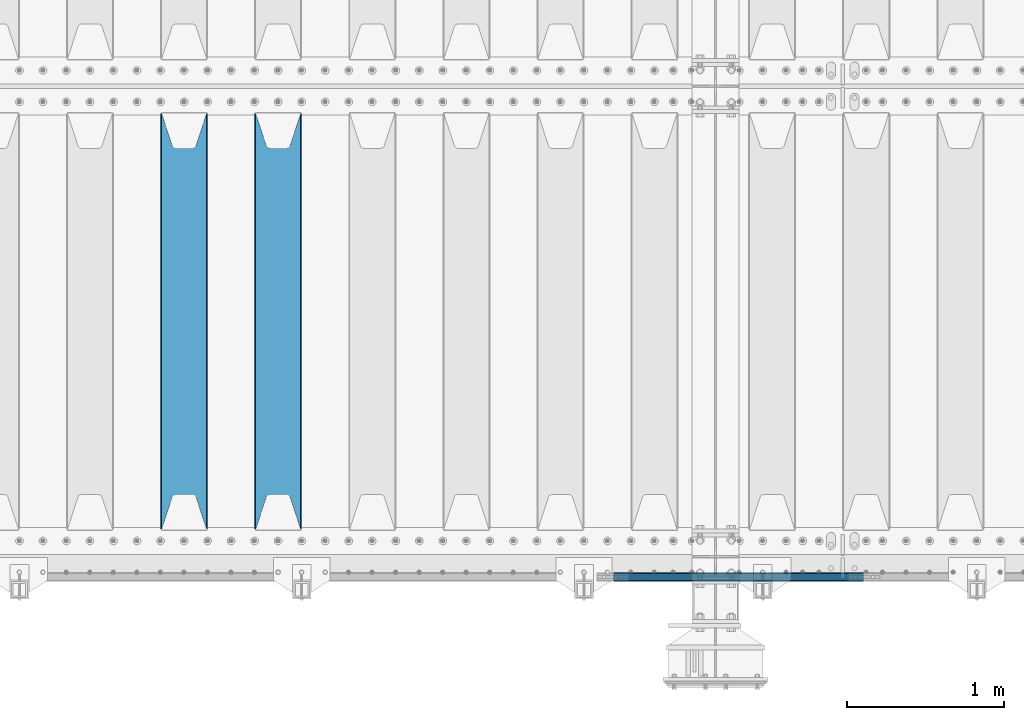
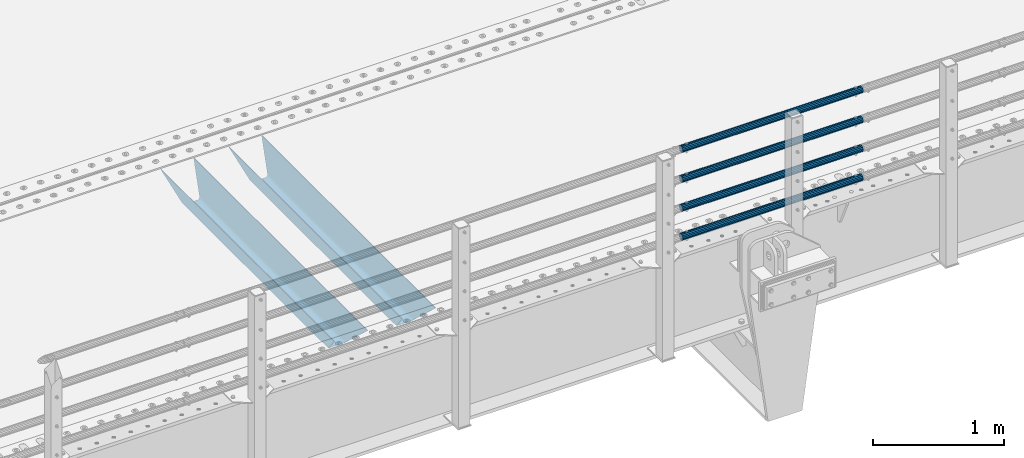
# One storey, part 105 of 240: 6 beams.
"""IFC2X3 building model written with IfcOpenShell, lengths in millimetres."""

import ifcopenshell
import ifcopenshell.guid

model = None  # the IFC model being written
_history = None  # IfcOwnerHistory: only IFC2X3 demands one
_inside = {}  # id of a spatial element -> (the spatial element, [elements in it])
_under = {}  # id of a project, library or spatial element -> (it, [spatial elements below it])
_declared = {}  # id of a project -> (the project, [libraries it declares])
_typed = {}  # id of a type object -> (the type object, [elements of that type])
_made_of = {}  # id of a material, layer set ... -> (it, [elements and type objects made of it])


def new_model(schema):
    """Start an empty IFC model of exactly this schema.

    Asked for "IFC4X3", IfcOpenShell would pick the latest addendum, in which some entities
    have other attributes; the version numbers below select the first issue.
    IFC2X3 requires an IfcOwnerHistory on every rooted entity: one is made here for all.
    """
    global model, _history
    if schema == "IFC4X3":
        model = ifcopenshell.file(schema_version=(4, 3, 0, 0))
    else:
        model = ifcopenshell.file(schema=schema)
    _inside.clear()
    _under.clear()
    _declared.clear()
    _typed.clear()
    _made_of.clear()
    _history = None
    if model.schema == "IFC2X3":
        org = make("IfcOrganization", Name="unknown")
        user = make(
            "IfcPersonAndOrganization",
            ThePerson=make("IfcPerson", FamilyName="unknown"),
            TheOrganization=org,
        )
        app = make(
            "IfcApplication",
            ApplicationDeveloper=org,
            Version="unknown",
            ApplicationFullName="unknown",
            ApplicationIdentifier="unknown",
        )
        _history = make(
            "IfcOwnerHistory",
            OwningUser=user,
            OwningApplication=app,
            ChangeAction="ADDED",
            CreationDate=0,
        )
    return model


def make(cls, **values):
    """One entity of the class cls with the attributes given. An attribute that is None is left unset."""
    return model.create_entity(
        cls, **{name: value for name, value in values.items() if value is not None}
    )


def rooted(cls, **values):
    """An entity with a GlobalId (a new one), such as an element, a storey or a relation."""
    return make(cls, GlobalId=ifcopenshell.guid.new(), OwnerHistory=_history, **values)


def si_unit(unit_type, name, prefix=None):
    """IfcSIUnit, for example si_unit("LENGTHUNIT", "METRE", prefix="MILLI")."""
    return make("IfcSIUnit", UnitType=unit_type, Prefix=prefix, Name=name)


def assignment(units):
    """IfcUnitAssignment: the units of a project."""
    return None if units is None else make("IfcUnitAssignment", Units=units)


def point(xyz):
    """IfcCartesianPoint."""
    return None if xyz is None else make("IfcCartesianPoint", Coordinates=xyz)


def direction(xyz):
    """IfcDirection."""
    return None if xyz is None else make("IfcDirection", DirectionRatios=xyz)


def frame(location, z_axis=None, x_axis=None):
    """IfcAxis2Placement3D, a coordinate frame: its origin and axes. An axis left out is left unset."""
    return make(
        "IfcAxis2Placement3D",
        Location=point(location),
        Axis=direction(z_axis),
        RefDirection=direction(x_axis),
    )


def origin_with_axes():
    """The frame at (0, 0, 0) with the z axis (0, 0, 1) and the x axis (1, 0, 0) written out."""
    return frame((0.0, 0.0, 0.0), z_axis=(0.0, 0.0, 1.0), x_axis=(1.0, 0.0, 0.0))


def place(relative_to, where):
    """IfcLocalPlacement: puts the frame where relative to a parent placement (None: the world)."""
    return make(
        "IfcLocalPlacement", PlacementRelTo=relative_to, RelativePlacement=where
    )


def context(
    kind, dimensions, precision=None, world=None, true_north=None, identifier=None
):
    """IfcGeometricRepresentationContext, for example the 3D "Model" context."""
    return make(
        "IfcGeometricRepresentationContext",
        ContextIdentifier=identifier,
        ContextType=kind,
        CoordinateSpaceDimension=dimensions,
        Precision=precision,
        WorldCoordinateSystem=world,
        TrueNorth=true_north,
    )


def subcontext(parent, identifier, kind, view, scale=None):
    """IfcGeometricRepresentationSubContext, for example "Body" below "Model"."""
    return make(
        "IfcGeometricRepresentationSubContext",
        ContextIdentifier=identifier,
        ContextType=kind,
        ParentContext=parent,
        TargetScale=scale,
        TargetView=view,
    )


def project(units=None, contexts=None):
    """IfcProject with its units and contexts."""
    return rooted(
        "IfcProject",
        Name="project",
        RepresentationContexts=contexts,
        UnitsInContext=assignment(units),
    )


def spatial(cls, under=None, at=None, **own):
    """A site, building, storey or space (cls), placed at a placement, below another one or the project."""
    s = rooted(cls, ObjectPlacement=at, **own)
    if under is not None:
        _under.setdefault(under.id(), (under, []))[1].append(s)
    return s


def faces_of(points, faces, orient=None, outer=None):
    """IfcFace entities. A face is a list of loops; a loop is a list of indices into points, from 0.

    orient and outer hold one flag for each loop. By default every Orientation is true, the
    first loop of a face is its IfcFaceOuterBound and the others are IfcFaceBound.
    """
    made = []
    for i, loops in enumerate(faces):
        bounds = []
        for j, loop in enumerate(loops):
            is_outer = j == 0 if outer is None else outer[i][j]
            bounds.append(
                make(
                    "IfcFaceOuterBound" if is_outer else "IfcFaceBound",
                    Bound=make("IfcPolyLoop", Polygon=[points[k] for k in loop]),
                    Orientation=True if orient is None else orient[i][j],
                )
            )
        made.append(make("IfcFace", Bounds=bounds))
    return made


def faceted_brep(points, faces, orient=None, outer=None, voids=None):
    """IfcFacetedBrep: a solid bounded by flat faces; with voids (closed shells), ...WithVoids."""
    shared = [point(p) for p in points]
    hull = make("IfcClosedShell", CfsFaces=faces_of(shared, faces, orient, outer))
    if voids is None:
        return make("IfcFacetedBrep", Outer=hull)
    return make(
        "IfcFacetedBrepWithVoids",
        Outer=hull,
        Voids=[
            make(cls, CfsFaces=faces_of(shared, fs, o, b)) for cls, fs, o, b in voids
        ],
    )


def shape(context_of_items, identifier, shape_type, items):
    """IfcShapeRepresentation: the items that make up one representation, for example the "Body"."""
    return make(
        "IfcShapeRepresentation",
        ContextOfItems=context_of_items,
        RepresentationIdentifier=identifier,
        RepresentationType=shape_type,
        Items=items,
    )


def material(Name=None, Category=None):
    """IfcMaterial."""
    return make("IfcMaterial", Name=Name, Category=Category)


def made_of(thing, what):
    """Note that an element or type object is made of a material, layer set ...; save() writes the relation."""
    if what is not None:
        _made_of.setdefault(what.id(), (what, []))[1].append(thing)
    return thing


def type_object(cls, material=None, **own):
    """A type object (cls), such as IfcWallType, which elements share."""
    return made_of(rooted(cls, **own), material)


def element(
    cls,
    number,
    at=None,
    inside=None,
    cuts=None,
    type_object=None,
    material=None,
    context=None,
    identifier="Body",
    shape_type=None,
    held_by="IfcProductDefinitionShape",
    body=None,
    shapes=None,
    **own,
):
    """One element of the class cls, such as IfcWall. Its Tag is "e" and its number.

    at: its placement. inside: the storey or other place that contains it. cuts: it is an
    opening in that element (IfcRelVoidsElement). A single representation is given by context,
    identifier, shape_type and body (its items); several are given by shapes. held_by: the class
    of the entity that holds the representations. save() writes the other relations.
    """
    e = rooted(cls, Tag="e%d" % number, ObjectPlacement=at, **own)
    if body is not None:
        shapes = [shape(context, identifier, shape_type, body)]
    if shapes is not None:
        e.Representation = make(held_by, Representations=shapes)
    if inside is not None:
        _inside.setdefault(inside.id(), (inside, []))[1].append(e)
    if cuts is not None:
        rooted(
            "IfcRelVoidsElement", RelatingBuildingElement=cuts, RelatedOpeningElement=e
        )
    if type_object is not None:
        _typed.setdefault(type_object.id(), (type_object, []))[1].append(e)
    return made_of(e, material)


def aggregate(whole, parts):
    """IfcRelAggregates: a whole, such as a stair, and the parts it consists of."""
    return rooted("IfcRelAggregates", RelatingObject=whole, RelatedObjects=parts)


def save(model, path):
    """Write the relations noted so far, then the file.

    IfcRelAggregates (storeys below a building ...), IfcRelContainedInSpatialStructure (elements
    in a storey), IfcRelDefinesByType, IfcRelAssociatesMaterial and IfcRelDeclares: one each for
    every whole, place, type object, material and project.
    """
    for whole, parts in _under.values():
        aggregate(whole, parts)
    for where, things in _inside.values():
        rooted(
            "IfcRelContainedInSpatialStructure",
            RelatedElements=things,
            RelatingStructure=where,
        )
    for kind, things in _typed.values():
        rooted("IfcRelDefinesByType", RelatedObjects=things, RelatingType=kind)
    for what, things in _made_of.values():
        rooted("IfcRelAssociatesMaterial", RelatedObjects=things, RelatingMaterial=what)
    for by, libraries in _declared.values():
        rooted("IfcRelDeclares", RelatingContext=by, RelatedDefinitions=libraries)
    model.write(path)


model = new_model("IFC2X3")

# Units and contexts
model_context = context("Model", 3, precision=1e-05, world=origin_with_axes())
body_context = subcontext(model_context, "Body", "Model", "MODEL_VIEW")
ifc_project = project(units=[si_unit("LENGTHUNIT", "METRE", prefix="MILLI"), si_unit("AREAUNIT", "SQUARE_METRE"), si_unit("VOLUMEUNIT", "CUBIC_METRE"), si_unit("MASSUNIT", "GRAM", prefix="KILO"), si_unit("TIMEUNIT", "SECOND"), si_unit("PLANEANGLEUNIT", "RADIAN"), si_unit("SOLIDANGLEUNIT", "STERADIAN"), si_unit("THERMODYNAMICTEMPERATUREUNIT", "DEGREE_CELSIUS"), si_unit("LUMINOUSINTENSITYUNIT", "LUMEN")], contexts=[model_context])

# Site, building, storey
site_placement = place(None, origin_with_axes())
site = spatial("IfcSite", under=ifc_project, at=site_placement, CompositionType="ELEMENT")
building_placement = place(site_placement, origin_with_axes())
building = spatial("IfcBuilding", under=site, at=building_placement, Name="Standard", CompositionType="ELEMENT")
storey_placement = place(building_placement, origin_with_axes())
storey = spatial("IfcBuildingStorey", under=building, at=storey_placement, Name="Undefined", CompositionType="ELEMENT", Elevation=0.0)

# Beams
ifc_material_1 = material(Name="STEEL/S355N")
beam_type_1 = type_object("IfcBeamType", PredefinedType="NOTDEFINED")
beam_1_placement = place(storey_placement, frame((50050.0, 24175.0, -115.0), z_axis=(0.0, 0.0, 1.0), x_axis=(0.0, 1.0, 0.0)))
element("IfcBeam", 1, at=beam_1_placement, inside=storey, type_object=beam_type_1, material=ifc_material_1, context=body_context, shape_type="Brep", body=[
    faceted_brep([(0.0, 150.0, 115.0), (0.0, 143.690000000002, 115.0), (2650.00000000297, 143.690000000002, 115.0), (2650.00000000297, 150.0, 115.0), (2650.00000000297, 142.059565218406, 110.000000003094), (2650.00000000297, 148.369565218403, 110.000000003094), (2441.90079219209, -80.1103600731149, -98.0992078077845), (2437.7588105432, -77.5672621345584, -102.241189456673), (2434.06523489747, -74.4080125315522, -105.934765102404), (2430.9108609509, -70.7102721255724, -109.089139048974), (2428.37322971128, -66.5649389910031, -111.626770288588), (2426.51472138055, -62.0739139532889, -113.485278619323), (2425.38102192092, -57.3475956567636, -114.618978078955), (2424.99999999987, -52.5021667386536, -115.0), (2424.99999999987, 52.5021667386536, -115.0), (2425.38102192092, 57.3475956567636, -114.618978078955), (2426.51472138055, 62.0739139532889, -113.485278619323), (2428.37322971128, 66.5649389910031, -111.626770288588), (2430.9108609509, 70.7102721255724, -109.089139048974), (2434.06523489747, 74.4080125315522, -105.934765102404), (2437.7588105432, 77.5672621345584, -102.241189456673), (2441.90079219209, 80.1103600731149, -98.0992078077846), (2446.38936140512, 81.9747917625791, -93.6106385947584), (2448.2494850041, 76.2713538057287, -91.7505149957729), (2444.62967112263, 74.76777986261, -95.3703288772456), (2441.28936334127, 72.7168944282894, -98.710636658607), (2438.31067330439, 70.1691124903809, -101.689326695487), (2435.76682334748, 67.1870637758839, -104.233176652398), (2433.72034654134, 63.8440531834931, -106.279653458539), (2432.22154950042, 60.2222587982324, -107.778450499454), (2431.30727574265, 56.4107117849126, -108.692724257221), (2430.99999999987, 52.5031078186876, -109.0), (2430.99999999987, -52.5031078186876, -109.0), (2431.30727574265, -56.4107117849126, -108.692724257221), (2432.22154950042, -60.2222587982324, -107.778450499454), (2433.72034654134, -63.8440531834931, -106.279653458539), (2435.76682334748, -67.1870637758839, -104.233176652398), (2438.31067330439, -70.1691124903809, -101.689326695487), (2441.28936334127, -72.7168944282894, -98.7106366586071), (2444.62967112263, -74.76777986261, -95.3703288772457), (2448.2494850041, -76.2713538057287, -91.7505149957729), (2650.00000000297, -142.059565218406, 110.000000003094), (2650.00000000297, -148.369565218403, 110.000000003094), (2446.38936140512, -81.9747917625791, -93.6106385947584), (2650.00000000297, -143.690000000002, 115.0), (2650.00000000297, -150.0, 115.0), (0.0, -143.690000000002, 115.0), (0.0, -150.0, 115.0), (0.0, -148.369565218258, 110.000000002667), (203.610638597427, -81.9747917625791, -93.6106385947584), (208.09920781045, -80.1103600731149, -98.0992078077845), (212.241189459342, -77.5672621345584, -102.241189456673), (215.93476510507, -74.4080125315522, -105.934765102404), (219.089139051641, -70.7102721255724, -109.089139048974), (221.626770291256, -66.5649389910031, -111.626770288588), (223.485278621989, -62.0739139532889, -113.485278619323), (224.618978081624, -57.3475956567636, -114.618978078955), (225.000000002663, -52.5021667386536, -115.0), (225.000000002663, 52.5021667386536, -115.0), (224.618978081624, 57.3475956567636, -114.618978078955), (223.485278621989, 62.0739139532889, -113.485278619323), (221.626770291256, 66.5649389910031, -111.626770288588), (219.089139051641, 70.7102721255724, -109.089139048974), (215.93476510507, 74.4080125315522, -105.934765102404), (212.241189459342, 77.5672621345584, -102.241189456673), (208.09920781045, 80.1103600731149, -98.0992078077846), (203.610638597427, 81.9747917625791, -93.6106385947584), (0.0, 148.369565218258, 110.000000002667), (0.0, 142.05956521826, 110.000000002667), (201.750514998439, 76.2713538057287, -91.7505149957729), (205.370328879908, 74.76777986261, -95.3703288772456), (208.710636661275, 72.7168944282894, -98.710636658607), (211.689326698153, 70.1691124903809, -101.689326695487), (214.233176655063, 67.1870637758839, -104.233176652398), (216.279653461206, 63.8440531834931, -106.279653458539), (217.778450502123, 60.2222587982324, -107.778450499454), (218.692724259887, 56.4107117849126, -108.692724257221), (219.000000002667, 52.5031078186876, -109.0), (219.000000002667, -52.5031078186876, -109.0), (218.692724259887, -56.4107117849126, -108.692724257221), (217.778450502123, -60.2222587982324, -107.778450499454), (216.279653461206, -63.8440531834931, -106.279653458539), (214.233176655063, -67.1870637758839, -104.233176652398), (211.689326698153, -70.1691124903809, -101.689326695487), (208.710636661275, -72.7168944282894, -98.7106366586071), (205.370328879915, -74.76777986261, -95.3703288772457), (201.750514998439, -76.2713538057287, -91.7505149957729), (0.0, -142.05956521826, 110.000000002667)], [[[0, 1, 2, 3]], [[3, 2, 4, 5]], [[6, 7, 8, 9, 10, 11, 12, 13, 14, 15, 16, 17, 18, 19, 20, 21, 22, 5, 4, 23, 24, 25, 26, 27, 28, 29, 30, 31, 32, 33, 34, 35, 36, 37, 38, 39, 40, 41, 42, 43]], [[44, 45, 42, 41]], [[46, 47, 45, 44]], [[43, 42, 45, 47, 48, 49]], [[6, 43, 49, 50]], [[7, 6, 50, 51]], [[8, 7, 51, 52]], [[9, 8, 52, 53]], [[10, 9, 53, 54]], [[11, 10, 54, 55]], [[12, 11, 55, 56]], [[13, 12, 56, 57]], [[14, 13, 57, 58]], [[15, 14, 58, 59]], [[16, 15, 59, 60]], [[17, 16, 60, 61]], [[18, 17, 61, 62]], [[19, 18, 62, 63]], [[20, 19, 63, 64]], [[21, 20, 64, 65]], [[22, 21, 65, 66]], [[0, 3, 5, 22, 66, 67]], [[1, 0, 67, 68]], [[23, 4, 2, 1, 68, 69]], [[24, 23, 69, 70]], [[25, 24, 70, 71]], [[26, 25, 71, 72]], [[27, 26, 72, 73]], [[28, 27, 73, 74]], [[29, 28, 74, 75]], [[30, 29, 75, 76]], [[31, 30, 76, 77]], [[32, 31, 77, 78]], [[33, 32, 78, 79]], [[34, 33, 79, 80]], [[35, 34, 80, 81]], [[36, 35, 81, 82]], [[37, 36, 82, 83]], [[38, 37, 83, 84]], [[39, 38, 84, 85]], [[40, 39, 85, 86]], [[46, 44, 41, 40, 86, 87]], [[47, 46, 87, 48]], [[86, 85, 84, 83, 82, 81, 80, 79, 78, 77, 76, 75, 74, 73, 72, 71, 70, 69, 68, 67, 66, 65, 64, 63, 62, 61, 60, 59, 58, 57, 56, 55, 54, 53, 52, 51, 50, 49, 48, 87]]]),
])
beam_2_placement = place(storey_placement, frame((49450.0, 24175.0, -115.0), z_axis=(0.0, 0.0, 1.0), x_axis=(0.0, 1.0, 0.0)))
element("IfcBeam", 2, at=beam_2_placement, inside=storey, type_object=beam_type_1, material=ifc_material_1, context=body_context, shape_type="Brep", body=[
    faceted_brep([(0.0, 150.0, 115.0), (0.0, 143.690000000002, 115.0), (2650.00000000297, 143.690000000002, 115.0), (2650.00000000297, 150.0, 115.0), (2650.00000000297, 142.059565218406, 110.000000003094), (2650.00000000297, 148.369565218403, 110.000000003094), (2441.90079219209, -80.1103600731149, -98.0992078077845), (2437.7588105432, -77.5672621345584, -102.241189456673), (2434.06523489747, -74.4080125315522, -105.934765102404), (2430.9108609509, -70.7102721255724, -109.089139048974), (2428.37322971128, -66.5649389910031, -111.626770288588), (2426.51472138055, -62.0739139532889, -113.485278619323), (2425.38102192092, -57.3475956567636, -114.618978078955), (2424.99999999987, -52.5021667386536, -115.0), (2424.99999999987, 52.5021667386536, -115.0), (2425.38102192092, 57.3475956567636, -114.618978078955), (2426.51472138055, 62.0739139532889, -113.485278619323), (2428.37322971128, 66.5649389910031, -111.626770288588), (2430.9108609509, 70.7102721255724, -109.089139048974), (2434.06523489747, 74.4080125315522, -105.934765102404), (2437.7588105432, 77.5672621345584, -102.241189456673), (2441.90079219209, 80.1103600731149, -98.0992078077846), (2446.38936140512, 81.9747917625791, -93.6106385947584), (2448.2494850041, 76.2713538057287, -91.7505149957729), (2444.62967112263, 74.76777986261, -95.3703288772456), (2441.28936334127, 72.7168944282894, -98.710636658607), (2438.31067330439, 70.1691124903809, -101.689326695487), (2435.76682334748, 67.1870637758839, -104.233176652398), (2433.72034654134, 63.8440531834931, -106.279653458539), (2432.22154950042, 60.2222587982324, -107.778450499454), (2431.30727574265, 56.4107117849126, -108.692724257221), (2430.99999999987, 52.5031078186876, -109.0), (2430.99999999987, -52.5031078186876, -109.0), (2431.30727574265, -56.4107117849126, -108.692724257221), (2432.22154950042, -60.2222587982324, -107.778450499454), (2433.72034654134, -63.8440531834931, -106.279653458539), (2435.76682334748, -67.1870637758839, -104.233176652398), (2438.31067330439, -70.1691124903809, -101.689326695487), (2441.28936334127, -72.7168944282894, -98.7106366586071), (2444.62967112263, -74.76777986261, -95.3703288772457), (2448.2494850041, -76.2713538057287, -91.7505149957729), (2650.00000000297, -142.059565218406, 110.000000003094), (2650.00000000297, -148.369565218403, 110.000000003094), (2446.38936140512, -81.9747917625791, -93.6106385947584), (2650.00000000297, -143.690000000002, 115.0), (2650.00000000297, -150.0, 115.0), (0.0, -143.690000000002, 115.0), (0.0, -150.0, 115.0), (0.0, -148.369565218258, 110.000000002667), (203.610638597427, -81.9747917625791, -93.6106385947584), (208.09920781045, -80.1103600731149, -98.0992078077845), (212.241189459342, -77.5672621345584, -102.241189456673), (215.93476510507, -74.4080125315522, -105.934765102404), (219.089139051641, -70.7102721255724, -109.089139048974), (221.626770291256, -66.5649389910031, -111.626770288588), (223.485278621989, -62.0739139532889, -113.485278619323), (224.618978081624, -57.3475956567636, -114.618978078955), (225.000000002663, -52.5021667386536, -115.0), (225.000000002663, 52.5021667386536, -115.0), (224.618978081624, 57.3475956567636, -114.618978078955), (223.485278621989, 62.0739139532889, -113.485278619323), (221.626770291256, 66.5649389910031, -111.626770288588), (219.089139051641, 70.7102721255724, -109.089139048974), (215.93476510507, 74.4080125315522, -105.934765102404), (212.241189459342, 77.5672621345584, -102.241189456673), (208.09920781045, 80.1103600731149, -98.0992078077846), (203.610638597427, 81.9747917625791, -93.6106385947584), (0.0, 148.369565218258, 110.000000002667), (0.0, 142.05956521826, 110.000000002667), (201.750514998439, 76.2713538057287, -91.7505149957729), (205.370328879908, 74.76777986261, -95.3703288772456), (208.710636661275, 72.7168944282894, -98.710636658607), (211.689326698153, 70.1691124903809, -101.689326695487), (214.233176655063, 67.1870637758839, -104.233176652398), (216.279653461206, 63.8440531834931, -106.279653458539), (217.778450502123, 60.2222587982324, -107.778450499454), (218.692724259887, 56.4107117849126, -108.692724257221), (219.000000002667, 52.5031078186876, -109.0), (219.000000002667, -52.5031078186876, -109.0), (218.692724259887, -56.4107117849126, -108.692724257221), (217.778450502123, -60.2222587982324, -107.778450499454), (216.279653461206, -63.8440531834931, -106.279653458539), (214.233176655063, -67.1870637758839, -104.233176652398), (211.689326698153, -70.1691124903809, -101.689326695487), (208.710636661275, -72.7168944282894, -98.7106366586071), (205.370328879915, -74.76777986261, -95.3703288772457), (201.750514998439, -76.2713538057287, -91.7505149957729), (0.0, -142.05956521826, 110.000000002667)], [[[0, 1, 2, 3]], [[3, 2, 4, 5]], [[6, 7, 8, 9, 10, 11, 12, 13, 14, 15, 16, 17, 18, 19, 20, 21, 22, 5, 4, 23, 24, 25, 26, 27, 28, 29, 30, 31, 32, 33, 34, 35, 36, 37, 38, 39, 40, 41, 42, 43]], [[44, 45, 42, 41]], [[46, 47, 45, 44]], [[43, 42, 45, 47, 48, 49]], [[6, 43, 49, 50]], [[7, 6, 50, 51]], [[8, 7, 51, 52]], [[9, 8, 52, 53]], [[10, 9, 53, 54]], [[11, 10, 54, 55]], [[12, 11, 55, 56]], [[13, 12, 56, 57]], [[14, 13, 57, 58]], [[15, 14, 58, 59]], [[16, 15, 59, 60]], [[17, 16, 60, 61]], [[18, 17, 61, 62]], [[19, 18, 62, 63]], [[20, 19, 63, 64]], [[21, 20, 64, 65]], [[22, 21, 65, 66]], [[0, 3, 5, 22, 66, 67]], [[1, 0, 67, 68]], [[23, 4, 2, 1, 68, 69]], [[24, 23, 69, 70]], [[25, 24, 70, 71]], [[26, 25, 71, 72]], [[27, 26, 72, 73]], [[28, 27, 73, 74]], [[29, 28, 74, 75]], [[30, 29, 75, 76]], [[31, 30, 76, 77]], [[32, 31, 77, 78]], [[33, 32, 78, 79]], [[34, 33, 79, 80]], [[35, 34, 80, 81]], [[36, 35, 81, 82]], [[37, 36, 82, 83]], [[38, 37, 83, 84]], [[39, 38, 84, 85]], [[40, 39, 85, 86]], [[46, 44, 41, 40, 86, 87]], [[47, 46, 87, 48]], [[86, 85, 84, 83, 82, 81, 80, 79, 78, 77, 76, 75, 74, 73, 72, 71, 70, 69, 68, 67, 66, 65, 64, 63, 62, 61, 60, 59, 58, 57, 56, 55, 54, 53, 52, 51, 50, 49, 48, 87]]]),
])
ifc_material_2 = material()
beam_type_2 = type_object("IfcBeamType", PredefinedType="NOTDEFINED")
beam_3_placement = place(storey_placement, frame((53781.9999999999, 23870.1500000002, 149.849999999748), z_axis=(0.0, 0.0, -1.0), x_axis=(-1.0, 0.0, 0.0)))
element("IfcBeam", 3, at=beam_3_placement, inside=storey, type_object=beam_type_2, material=ifc_material_2, context=body_context, shape_type="Brep", body=[
    faceted_brep([(0.0, -26.5500000000029, 0.0), (0.0, -24.5290015881765, 10.1602451292931), (1594.0, -24.5290015881765, 10.1602451292931), (1594.0, -26.5500000000029, 0.0), (0.0, -18.7736850405054, 18.7736850405028), (1594.0, -18.7736850405054, 18.7736850405028), (0.0, -10.1602451292929, 24.5290015881747), (1594.0, -10.1602451292929, 24.5290015881747), (0.0, 0.0, 26.55), (1594.0, 0.0, 26.55), (0.0, 10.1602451292929, 24.5290015881747), (1594.0, 10.1602451292929, 24.5290015881747), (0.0, 18.7736850405054, 18.7736850405028), (1594.0, 18.7736850405054, 18.7736850405028), (0.0, 24.5290015881765, 10.1602451292931), (1594.0, 24.5290015881765, 10.1602451292931), (0.0, 26.5500000000029, 0.0), (1594.0, 26.5500000000029, 0.0), (0.0, 24.5290015881765, -10.1602451292931), (1594.0, 24.5290015881765, -10.1602451292931), (0.0, 18.7736850405054, -18.7736850405028), (1594.0, 18.7736850405054, -18.7736850405028), (0.0, 10.1602451292929, -24.5290015881747), (1594.0, 10.1602451292929, -24.5290015881747), (0.0, 0.0, -26.55), (1594.0, 0.0, -26.55), (0.0, -10.1602451292929, -24.5290015881747), (1594.0, -10.1602451292929, -24.5290015881747), (0.0, -18.7736850405054, -18.7736850405028), (1594.0, -18.7736850405054, -18.7736850405028), (0.0, -24.5290015881765, -10.1602451292931), (1594.0, -24.5290015881765, -10.1602451292931), (0.0, -30.1500000000015, 0.0), (0.0, -27.8549679052157, -11.5379054858058), (1594.0, -27.8549679052157, -11.5379054858075), (1594.0, -30.1500000000015, 0.0), (0.0, -21.3192694527752, -21.3192694527752), (1594.0, -21.3192694527752, -21.3192694527744), (0.0, -11.5379054858058, -27.8549679052157), (1594.0, -11.5379054858058, -27.8549679052153), (0.0, 0.0, -30.1500000000015), (1594.0, 0.0, -30.15), (0.0, 11.5379054858058, -27.8549679052157), (1594.0, 11.5379054858058, -27.8549679052153), (0.0, 21.3192694527752, -21.3192694527752), (1594.0, 21.3192694527752, -21.3192694527744), (0.0, 27.8549679052157, -11.5379054858058), (1594.0, 27.8549679052157, -11.5379054858074), (0.0, 30.1500000000015, 0.0), (1594.0, 30.1500000000015, 0.0), (0.0, 27.8549679052157, 11.5379054858058), (1594.0, 27.8549679052157, 11.5379054858075), (0.0, 21.3192694527752, 21.3192694527752), (1594.0, 21.3192694527752, 21.3192694527744), (0.0, 11.5379054858058, 27.8549679052157), (1594.0, 11.5379054858058, 27.8549679052153), (0.0, 0.0, 30.1500000000015), (1594.0, 0.0, 30.15), (0.0, -11.5379054858058, 27.8549679052157), (1594.0, -11.5379054858058, 27.8549679052153), (0.0, -21.3192694527752, 21.3192694527752), (1594.0, -21.3192694527752, 21.3192694527744), (0.0, -27.8549679052157, 11.5379054858058), (1594.0, -27.8549679052157, 11.5379054858075)], [[[0, 1, 2, 3]], [[1, 4, 5, 2]], [[4, 6, 7, 5]], [[6, 8, 9, 7]], [[8, 10, 11, 9]], [[10, 12, 13, 11]], [[12, 14, 15, 13]], [[14, 16, 17, 15]], [[16, 18, 19, 17]], [[18, 20, 21, 19]], [[20, 22, 23, 21]], [[22, 24, 25, 23]], [[24, 26, 27, 25]], [[26, 28, 29, 27]], [[28, 30, 31, 29]], [[30, 0, 3, 31]], [[32, 33, 34, 35]], [[33, 36, 37, 34]], [[36, 38, 39, 37]], [[38, 40, 41, 39]], [[40, 42, 43, 41]], [[42, 44, 45, 43]], [[44, 46, 47, 45]], [[46, 48, 49, 47]], [[48, 50, 51, 49]], [[50, 52, 53, 51]], [[52, 54, 55, 53]], [[54, 56, 57, 55]], [[56, 58, 59, 57]], [[58, 60, 61, 59]], [[60, 62, 63, 61]], [[62, 32, 35, 63]], [[37, 39, 41, 43, 45, 47, 49, 51, 53, 55, 57, 59, 61, 63, 35, 34], [5, 7, 9, 11, 13, 15, 17, 19, 21, 23, 25, 27, 29, 31, 3, 2]], [[62, 60, 58, 56, 54, 52, 50, 48, 46, 44, 42, 40, 38, 36, 33, 32], [30, 28, 26, 24, 22, 20, 18, 16, 14, 12, 10, 8, 6, 4, 1, 0]]]),
])
beam_4_placement = place(storey_placement, frame((53781.9999999999, 23870.1500000002, 420.149999999748), z_axis=(0.0, 0.0, -1.0), x_axis=(-1.0, 0.0, 0.0)))
element("IfcBeam", 4, at=beam_4_placement, inside=storey, type_object=beam_type_2, material=ifc_material_2, context=body_context, shape_type="Brep", body=[
    faceted_brep([(0.0, -26.5500000000029, 0.0), (0.0, -24.5290015881765, 10.1602451292931), (1594.0, -24.5290015881765, 10.1602451292931), (1594.0, -26.5500000000029, 0.0), (0.0, -18.7736850405054, 18.7736850405028), (1594.0, -18.7736850405054, 18.7736850405028), (0.0, -10.1602451292929, 24.5290015881747), (1594.0, -10.1602451292929, 24.5290015881747), (0.0, 0.0, 26.55), (1594.0, 0.0, 26.55), (0.0, 10.1602451292929, 24.5290015881747), (1594.0, 10.1602451292929, 24.5290015881747), (0.0, 18.7736850405054, 18.7736850405028), (1594.0, 18.7736850405054, 18.7736850405028), (0.0, 24.5290015881765, 10.1602451292931), (1594.0, 24.5290015881765, 10.1602451292931), (0.0, 26.5500000000029, 0.0), (1594.0, 26.5500000000029, 0.0), (0.0, 24.5290015881765, -10.1602451292931), (1594.0, 24.5290015881765, -10.1602451292931), (0.0, 18.7736850405054, -18.7736850405028), (1594.0, 18.7736850405054, -18.7736850405028), (0.0, 10.1602451292929, -24.5290015881747), (1594.0, 10.1602451292929, -24.5290015881747), (0.0, 0.0, -26.55), (1594.0, 0.0, -26.55), (0.0, -10.1602451292929, -24.5290015881747), (1594.0, -10.1602451292929, -24.5290015881747), (0.0, -18.7736850405054, -18.7736850405028), (1594.0, -18.7736850405054, -18.7736850405028), (0.0, -24.5290015881765, -10.1602451292931), (1594.0, -24.5290015881765, -10.1602451292931), (0.0, -30.1500000000015, 0.0), (0.0, -27.8549679052157, -11.5379054858058), (1594.0, -27.8549679052157, -11.5379054858075), (1594.0, -30.1500000000015, 0.0), (0.0, -21.3192694527752, -21.3192694527752), (1594.0, -21.3192694527752, -21.3192694527744), (0.0, -11.5379054858058, -27.8549679052157), (1594.0, -11.5379054858058, -27.8549679052153), (0.0, 0.0, -30.1500000000015), (1594.0, 0.0, -30.15), (0.0, 11.5379054858058, -27.8549679052157), (1594.0, 11.5379054858058, -27.8549679052153), (0.0, 21.3192694527752, -21.3192694527752), (1594.0, 21.3192694527752, -21.3192694527744), (0.0, 27.8549679052157, -11.5379054858058), (1594.0, 27.8549679052157, -11.5379054858074), (0.0, 30.1500000000015, 0.0), (1594.0, 30.1500000000015, 0.0), (0.0, 27.8549679052157, 11.5379054858058), (1594.0, 27.8549679052157, 11.5379054858075), (0.0, 21.3192694527752, 21.3192694527752), (1594.0, 21.3192694527752, 21.3192694527744), (0.0, 11.5379054858058, 27.8549679052157), (1594.0, 11.5379054858058, 27.8549679052153), (0.0, 0.0, 30.1500000000015), (1594.0, 0.0, 30.15), (0.0, -11.5379054858058, 27.8549679052157), (1594.0, -11.5379054858058, 27.8549679052153), (0.0, -21.3192694527752, 21.3192694527752), (1594.0, -21.3192694527752, 21.3192694527744), (0.0, -27.8549679052157, 11.5379054858058), (1594.0, -27.8549679052157, 11.5379054858075)], [[[0, 1, 2, 3]], [[1, 4, 5, 2]], [[4, 6, 7, 5]], [[6, 8, 9, 7]], [[8, 10, 11, 9]], [[10, 12, 13, 11]], [[12, 14, 15, 13]], [[14, 16, 17, 15]], [[16, 18, 19, 17]], [[18, 20, 21, 19]], [[20, 22, 23, 21]], [[22, 24, 25, 23]], [[24, 26, 27, 25]], [[26, 28, 29, 27]], [[28, 30, 31, 29]], [[30, 0, 3, 31]], [[32, 33, 34, 35]], [[33, 36, 37, 34]], [[36, 38, 39, 37]], [[38, 40, 41, 39]], [[40, 42, 43, 41]], [[42, 44, 45, 43]], [[44, 46, 47, 45]], [[46, 48, 49, 47]], [[48, 50, 51, 49]], [[50, 52, 53, 51]], [[52, 54, 55, 53]], [[54, 56, 57, 55]], [[56, 58, 59, 57]], [[58, 60, 61, 59]], [[60, 62, 63, 61]], [[62, 32, 35, 63]], [[37, 39, 41, 43, 45, 47, 49, 51, 53, 55, 57, 59, 61, 63, 35, 34], [5, 7, 9, 11, 13, 15, 17, 19, 21, 23, 25, 27, 29, 31, 3, 2]], [[62, 60, 58, 56, 54, 52, 50, 48, 46, 44, 42, 40, 38, 36, 33, 32], [30, 28, 26, 24, 22, 20, 18, 16, 14, 12, 10, 8, 6, 4, 1, 0]]]),
])
beam_5_placement = place(storey_placement, frame((53781.9999999999, 23870.1500000002, 969.849999999748), z_axis=(0.0, 0.0, -1.0), x_axis=(-1.0, 0.0, 0.0)))
element("IfcBeam", 5, at=beam_5_placement, inside=storey, type_object=beam_type_2, material=ifc_material_2, context=body_context, shape_type="Brep", body=[
    faceted_brep([(0.0, -26.5500000000029, 0.0), (0.0, -24.5290015881765, 10.1602451292931), (1594.0, -24.5290015881765, 10.1602451292931), (1594.0, -26.5500000000029, 0.0), (0.0, -18.7736850405054, 18.7736850405028), (1594.0, -18.7736850405054, 18.7736850405028), (0.0, -10.1602451292929, 24.5290015881747), (1594.0, -10.1602451292929, 24.5290015881747), (0.0, 0.0, 26.55), (1594.0, 0.0, 26.55), (0.0, 10.1602451292929, 24.5290015881747), (1594.0, 10.1602451292929, 24.5290015881747), (0.0, 18.7736850405054, 18.7736850405028), (1594.0, 18.7736850405054, 18.7736850405028), (0.0, 24.5290015881765, 10.1602451292931), (1594.0, 24.5290015881765, 10.1602451292931), (0.0, 26.5500000000029, 0.0), (1594.0, 26.5500000000029, 0.0), (0.0, 24.5290015881765, -10.1602451292931), (1594.0, 24.5290015881765, -10.1602451292931), (0.0, 18.7736850405054, -18.7736850405028), (1594.0, 18.7736850405054, -18.7736850405028), (0.0, 10.1602451292929, -24.5290015881747), (1594.0, 10.1602451292929, -24.5290015881747), (0.0, 0.0, -26.55), (1594.0, 0.0, -26.55), (0.0, -10.1602451292929, -24.5290015881747), (1594.0, -10.1602451292929, -24.5290015881747), (0.0, -18.7736850405054, -18.7736850405028), (1594.0, -18.7736850405054, -18.7736850405028), (0.0, -24.5290015881765, -10.1602451292931), (1594.0, -24.5290015881765, -10.1602451292931), (0.0, -30.1500000000015, 0.0), (0.0, -27.8549679052157, -11.5379054858058), (1594.0, -27.8549679052157, -11.5379054858075), (1594.0, -30.1500000000015, 0.0), (0.0, -21.3192694527752, -21.3192694527752), (1594.0, -21.3192694527752, -21.3192694527744), (0.0, -11.5379054858058, -27.8549679052157), (1594.0, -11.5379054858058, -27.8549679052153), (0.0, 0.0, -30.1500000000015), (1594.0, 0.0, -30.15), (0.0, 11.5379054858058, -27.8549679052157), (1594.0, 11.5379054858058, -27.8549679052153), (0.0, 21.3192694527752, -21.3192694527752), (1594.0, 21.3192694527752, -21.3192694527744), (0.0, 27.8549679052157, -11.5379054858058), (1594.0, 27.8549679052157, -11.5379054858074), (0.0, 30.1500000000015, 0.0), (1594.0, 30.1500000000015, 0.0), (0.0, 27.8549679052157, 11.5379054858058), (1594.0, 27.8549679052157, 11.5379054858075), (0.0, 21.3192694527752, 21.3192694527752), (1594.0, 21.3192694527752, 21.3192694527744), (0.0, 11.5379054858058, 27.8549679052157), (1594.0, 11.5379054858058, 27.8549679052153), (0.0, 0.0, 30.1500000000015), (1594.0, 0.0, 30.15), (0.0, -11.5379054858058, 27.8549679052157), (1594.0, -11.5379054858058, 27.8549679052153), (0.0, -21.3192694527752, 21.3192694527752), (1594.0, -21.3192694527752, 21.3192694527744), (0.0, -27.8549679052157, 11.5379054858058), (1594.0, -27.8549679052157, 11.5379054858075)], [[[0, 1, 2, 3]], [[1, 4, 5, 2]], [[4, 6, 7, 5]], [[6, 8, 9, 7]], [[8, 10, 11, 9]], [[10, 12, 13, 11]], [[12, 14, 15, 13]], [[14, 16, 17, 15]], [[16, 18, 19, 17]], [[18, 20, 21, 19]], [[20, 22, 23, 21]], [[22, 24, 25, 23]], [[24, 26, 27, 25]], [[26, 28, 29, 27]], [[28, 30, 31, 29]], [[30, 0, 3, 31]], [[32, 33, 34, 35]], [[33, 36, 37, 34]], [[36, 38, 39, 37]], [[38, 40, 41, 39]], [[40, 42, 43, 41]], [[42, 44, 45, 43]], [[44, 46, 47, 45]], [[46, 48, 49, 47]], [[48, 50, 51, 49]], [[50, 52, 53, 51]], [[52, 54, 55, 53]], [[54, 56, 57, 55]], [[56, 58, 59, 57]], [[58, 60, 61, 59]], [[60, 62, 63, 61]], [[62, 32, 35, 63]], [[37, 39, 41, 43, 45, 47, 49, 51, 53, 55, 57, 59, 61, 63, 35, 34], [5, 7, 9, 11, 13, 15, 17, 19, 21, 23, 25, 27, 29, 31, 3, 2]], [[62, 60, 58, 56, 54, 52, 50, 48, 46, 44, 42, 40, 38, 36, 33, 32], [30, 28, 26, 24, 22, 20, 18, 16, 14, 12, 10, 8, 6, 4, 1, 0]]]),
])
beam_6_placement = place(storey_placement, frame((53781.9999999999, 23870.1500000002, 689.849999999748), z_axis=(0.0, 0.0, -1.0), x_axis=(-1.0, 0.0, 0.0)))
element("IfcBeam", 6, at=beam_6_placement, inside=storey, type_object=beam_type_2, material=ifc_material_2, context=body_context, shape_type="Brep", body=[
    faceted_brep([(0.0, -26.5500000000029, 0.0), (0.0, -24.5290015881765, 10.1602451292931), (1594.0, -24.5290015881765, 10.1602451292931), (1594.0, -26.5500000000029, 0.0), (0.0, -18.7736850405054, 18.7736850405028), (1594.0, -18.7736850405054, 18.7736850405028), (0.0, -10.1602451292929, 24.5290015881747), (1594.0, -10.1602451292929, 24.5290015881747), (0.0, 0.0, 26.55), (1594.0, 0.0, 26.55), (0.0, 10.1602451292929, 24.5290015881747), (1594.0, 10.1602451292929, 24.5290015881747), (0.0, 18.7736850405054, 18.7736850405028), (1594.0, 18.7736850405054, 18.7736850405028), (0.0, 24.5290015881765, 10.1602451292931), (1594.0, 24.5290015881765, 10.1602451292931), (0.0, 26.5500000000029, 0.0), (1594.0, 26.5500000000029, 0.0), (0.0, 24.5290015881765, -10.1602451292931), (1594.0, 24.5290015881765, -10.1602451292931), (0.0, 18.7736850405054, -18.7736850405028), (1594.0, 18.7736850405054, -18.7736850405028), (0.0, 10.1602451292929, -24.5290015881747), (1594.0, 10.1602451292929, -24.5290015881747), (0.0, 0.0, -26.55), (1594.0, 0.0, -26.55), (0.0, -10.1602451292929, -24.5290015881747), (1594.0, -10.1602451292929, -24.5290015881747), (0.0, -18.7736850405054, -18.7736850405028), (1594.0, -18.7736850405054, -18.7736850405028), (0.0, -24.5290015881765, -10.1602451292931), (1594.0, -24.5290015881765, -10.1602451292931), (0.0, -30.1500000000015, 0.0), (0.0, -27.8549679052157, -11.5379054858058), (1594.0, -27.8549679052157, -11.5379054858075), (1594.0, -30.1500000000015, 0.0), (0.0, -21.3192694527752, -21.3192694527752), (1594.0, -21.3192694527752, -21.3192694527744), (0.0, -11.5379054858058, -27.8549679052157), (1594.0, -11.5379054858058, -27.8549679052153), (0.0, 0.0, -30.1500000000015), (1594.0, 0.0, -30.15), (0.0, 11.5379054858058, -27.8549679052157), (1594.0, 11.5379054858058, -27.8549679052153), (0.0, 21.3192694527752, -21.3192694527752), (1594.0, 21.3192694527752, -21.3192694527744), (0.0, 27.8549679052157, -11.5379054858058), (1594.0, 27.8549679052157, -11.5379054858074), (0.0, 30.1500000000015, 0.0), (1594.0, 30.1500000000015, 0.0), (0.0, 27.8549679052157, 11.5379054858058), (1594.0, 27.8549679052157, 11.5379054858075), (0.0, 21.3192694527752, 21.3192694527752), (1594.0, 21.3192694527752, 21.3192694527744), (0.0, 11.5379054858058, 27.8549679052157), (1594.0, 11.5379054858058, 27.8549679052153), (0.0, 0.0, 30.1500000000015), (1594.0, 0.0, 30.15), (0.0, -11.5379054858058, 27.8549679052157), (1594.0, -11.5379054858058, 27.8549679052153), (0.0, -21.3192694527752, 21.3192694527752), (1594.0, -21.3192694527752, 21.3192694527744), (0.0, -27.8549679052157, 11.5379054858058), (1594.0, -27.8549679052157, 11.5379054858075)], [[[0, 1, 2, 3]], [[1, 4, 5, 2]], [[4, 6, 7, 5]], [[6, 8, 9, 7]], [[8, 10, 11, 9]], [[10, 12, 13, 11]], [[12, 14, 15, 13]], [[14, 16, 17, 15]], [[16, 18, 19, 17]], [[18, 20, 21, 19]], [[20, 22, 23, 21]], [[22, 24, 25, 23]], [[24, 26, 27, 25]], [[26, 28, 29, 27]], [[28, 30, 31, 29]], [[30, 0, 3, 31]], [[32, 33, 34, 35]], [[33, 36, 37, 34]], [[36, 38, 39, 37]], [[38, 40, 41, 39]], [[40, 42, 43, 41]], [[42, 44, 45, 43]], [[44, 46, 47, 45]], [[46, 48, 49, 47]], [[48, 50, 51, 49]], [[50, 52, 53, 51]], [[52, 54, 55, 53]], [[54, 56, 57, 55]], [[56, 58, 59, 57]], [[58, 60, 61, 59]], [[60, 62, 63, 61]], [[62, 32, 35, 63]], [[37, 39, 41, 43, 45, 47, 49, 51, 53, 55, 57, 59, 61, 63, 35, 34], [5, 7, 9, 11, 13, 15, 17, 19, 21, 23, 25, 27, 29, 31, 3, 2]], [[62, 60, 58, 56, 54, 52, 50, 48, 46, 44, 42, 40, 38, 36, 33, 32], [30, 28, 26, 24, 22, 20, 18, 16, 14, 12, 10, 8, 6, 4, 1, 0]]]),
])

save(model, "model.ifc")
